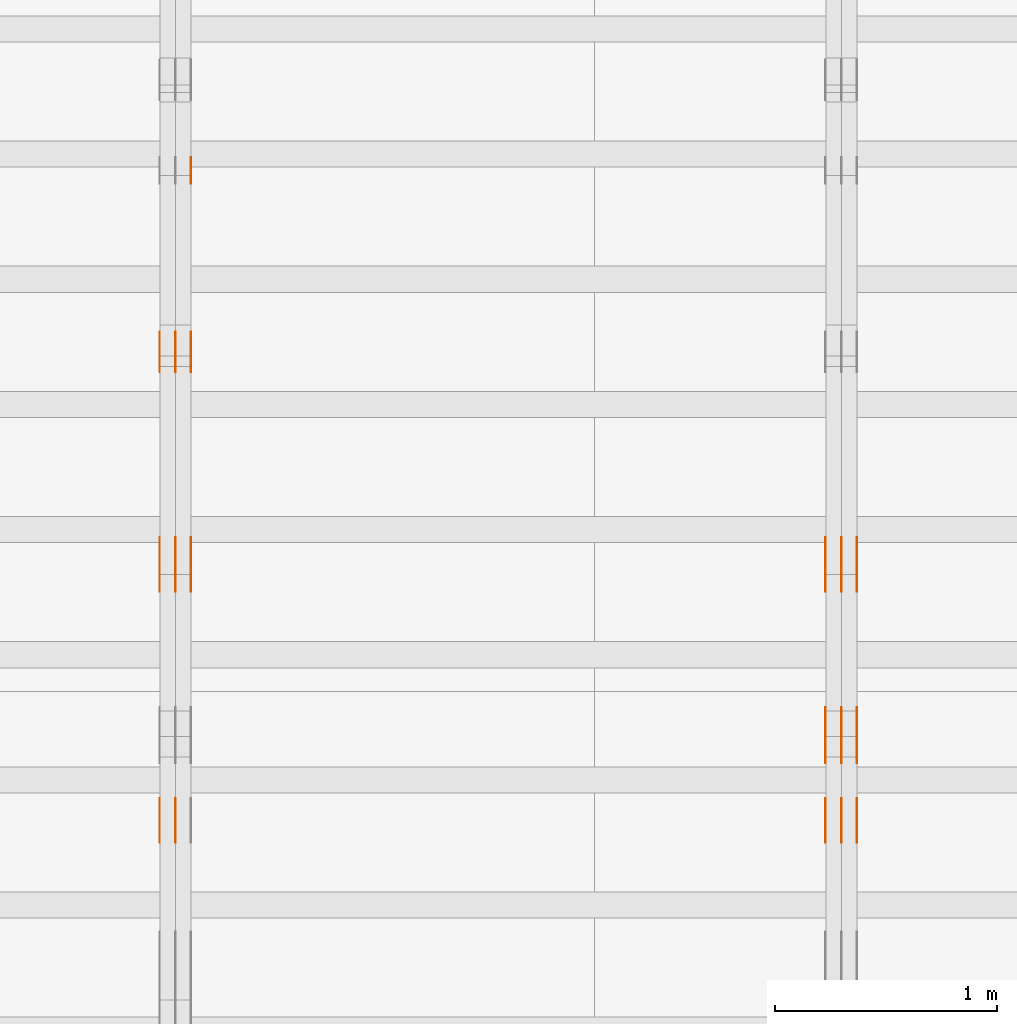
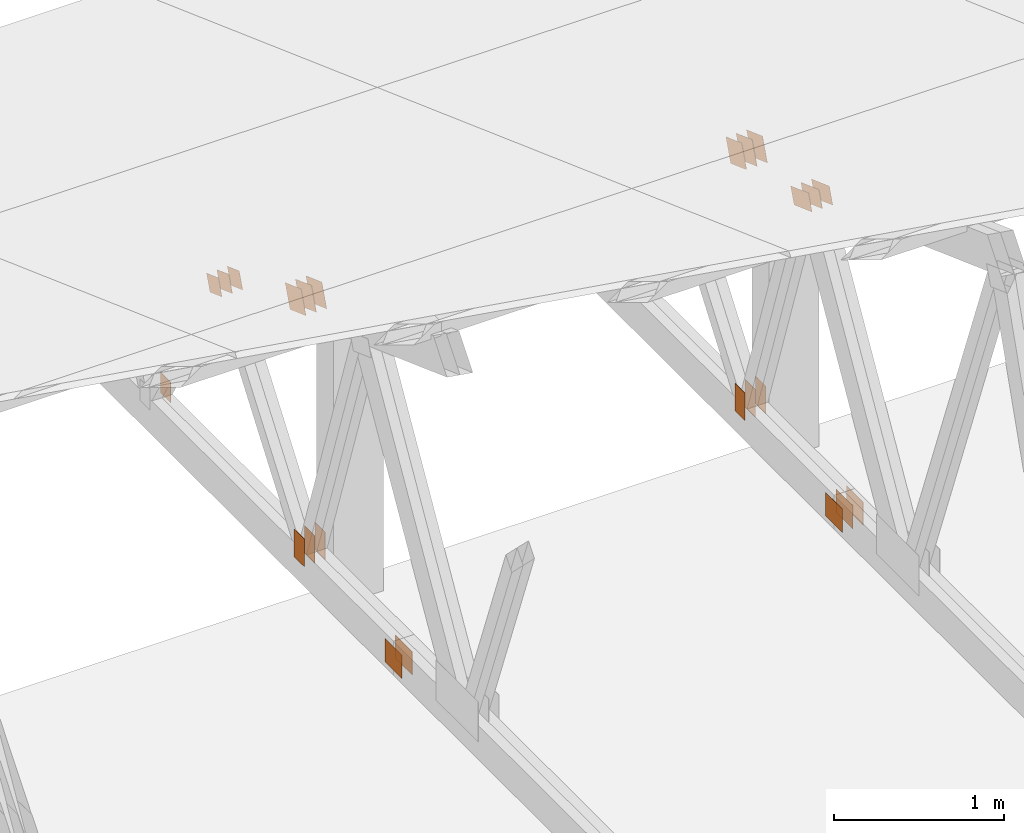
# One storey, part 112 of 189: 32 proxies.
"""IFC2X3 building model written with IfcOpenShell, lengths in millimetres."""

from ifc_helpers import new_model, entity, si_unit, converted_unit, derived_unit, direction, frame, frame_2d, origin, origin_2d_with_axis, place, context, subcontext, project, spatial, polyline, rectangle, outline, extrude, source, transform, mapped, material, type_object, type_shapes, element, save


model = new_model("IFC2X3")

# Units and contexts
model_context = context("Model", 3, precision=0.01, world=origin(), true_north=direction((6.12303176911189e-17, 1.0)))
body_context = subcontext(model_context, "Body", "Model", "MODEL_VIEW")
ifc_project = project(units=[si_unit("LENGTHUNIT", "METRE", prefix="MILLI"), si_unit("AREAUNIT", "SQUARE_METRE"), si_unit("VOLUMEUNIT", "CUBIC_METRE"), converted_unit("PLANEANGLEUNIT", "DEGREE", entity("IfcRatioMeasure", 0.0174532925199433), si_unit("PLANEANGLEUNIT", "RADIAN"), dimensions=[0, 0, 0, 0, 0, 0, 0]), si_unit("MASSUNIT", "GRAM", prefix="KILO"), derived_unit("MASSDENSITYUNIT", [(si_unit("MASSUNIT", "GRAM", prefix="KILO"), 1), (si_unit("LENGTHUNIT", "METRE"), -3)]), si_unit("TIMEUNIT", "SECOND"), si_unit("FREQUENCYUNIT", "HERTZ"), si_unit("THERMODYNAMICTEMPERATUREUNIT", "DEGREE_CELSIUS"), derived_unit("THERMALTRANSMITTANCEUNIT", [(si_unit("MASSUNIT", "GRAM", prefix="KILO"), 1), (si_unit("THERMODYNAMICTEMPERATUREUNIT", "KELVIN"), -1), (si_unit("TIMEUNIT", "SECOND"), -3)]), derived_unit("VOLUMETRICFLOWRATEUNIT", [(si_unit("LENGTHUNIT", "METRE"), 3), (si_unit("TIMEUNIT", "SECOND"), -1)]), si_unit("ELECTRICCURRENTUNIT", "AMPERE"), si_unit("ELECTRICVOLTAGEUNIT", "VOLT"), si_unit("POWERUNIT", "WATT"), si_unit("FORCEUNIT", "NEWTON"), si_unit("ILLUMINANCEUNIT", "LUX"), si_unit("LUMINOUSFLUXUNIT", "LUMEN"), si_unit("LUMINOUSINTENSITYUNIT", "CANDELA"), derived_unit("USERDEFINED", [(si_unit("MASSUNIT", "GRAM", prefix="KILO"), -1), (si_unit("LENGTHUNIT", "METRE"), -2), (si_unit("TIMEUNIT", "SECOND"), 3), (si_unit("LUMINOUSFLUXUNIT", "LUMEN"), 1)]), derived_unit("LINEARVELOCITYUNIT", [(si_unit("LENGTHUNIT", "METRE"), 1), (si_unit("TIMEUNIT", "SECOND"), -1)]), si_unit("PRESSUREUNIT", "PASCAL"), derived_unit("USERDEFINED", [(si_unit("LENGTHUNIT", "METRE"), -2), (si_unit("MASSUNIT", "GRAM", prefix="KILO"), 1), (si_unit("TIMEUNIT", "SECOND"), -2)])], contexts=[model_context])

# Site, building, storey
site_placement = place(None, origin())
site = spatial("IfcSite", under=ifc_project, at=site_placement, CompositionType="ELEMENT")
building_placement = place(site_placement, origin())
building = spatial("IfcBuilding", under=site, at=building_placement, CompositionType="ELEMENT")
storey_placement = place(building_placement, origin())
storey = spatial("IfcBuildingStorey", under=building, at=storey_placement, Name="Default", CompositionType="ELEMENT", Elevation=0.0)

# Proxies
ifc_material_1 = material(Name="IfcSurfaceStyle #43318")
building_element_proxy_type_1 = type_object("IfcBuildingElementProxyType", PredefinedType="NOTDEFINED", material=ifc_material_1)
shared_shape_1 = source(origin(), body_context, "Body", "SweptSolid", [
    extrude(outline(polyline([(-112.499846801582, -59.999986193028), (112.499924372729, -59.999986193028), (112.499888552087, 59.999986193028), (-112.499966123235, 59.999986193028), (-112.499846801582, -59.999986193028)])), frame((112.499989807712, 60.0001003787081, 0.0), z_axis=(0.0, 0.0, 1.0), x_axis=(-1.0, 0.0, 0.0)), (0.0, 0.0, 1.0), 1.3),
])
type_shapes(building_element_proxy_type_1, [shared_shape_1])
proxy_1_placement = place(building_placement, frame((6336.3, 24040.8868138992, 2049.61031693104), z_axis=(-1.0, 0.0, 0.0), x_axis=(0.0, -0.939692620785908, 0.342020143325669)))
element("IfcBuildingElementProxy", 1, at=proxy_1_placement, inside=storey, type_object=building_element_proxy_type_1, material=ifc_material_1, context=body_context, shape_type="MappedRepresentation", body=[
    mapped(shared_shape_1, transform((0.0, 0.0, 0.0), scale=1.0)),
])
ifc_material_2 = material(Name="IfcSurfaceStyle #43261")
building_element_proxy_type_2 = type_object("IfcBuildingElementProxyType", PredefinedType="NOTDEFINED", material=ifc_material_2)
shared_shape_2 = source(origin(), body_context, "Body", "SweptSolid", [
    extrude(outline(polyline([(-112.499846801582, -59.999986193028), (112.499924372729, -59.999986193028), (112.499888552087, 59.999986193028), (-112.499966123235, 59.999986193028), (-112.499846801582, -59.999986193028)])), frame((112.499989807712, 60.0001003787081, 0.0), z_axis=(0.0, 0.0, 1.0), x_axis=(-1.0, 0.0, 0.0)), (0.0, 0.0, 1.0), 1.29999999999998),
])
type_shapes(building_element_proxy_type_2, [shared_shape_2])
proxy_2_placement = place(building_placement, frame((6265.0, 24040.8868138992, 2049.61031693104), z_axis=(-1.0, 0.0, 0.0), x_axis=(0.0, -0.939692620785908, 0.342020143325669)))
element("IfcBuildingElementProxy", 2, at=proxy_2_placement, inside=storey, type_object=building_element_proxy_type_2, material=ifc_material_2, context=body_context, shape_type="MappedRepresentation", body=[
    mapped(shared_shape_2, transform((0.0, 0.0, 0.0), scale=1.0)),
])
ifc_material_3 = material(Name="IfcSurfaceStyle #43204")
building_element_proxy_type_3 = type_object("IfcBuildingElementProxyType", PredefinedType="NOTDEFINED", material=ifc_material_3)
shared_shape_3 = source(origin(), body_context, "Body", "SweptSolid", [
    extrude(outline(polyline([(-112.499846801582, -59.999986193028), (112.499924372729, -59.999986193028), (112.499888552087, 59.999986193028), (-112.499966123235, 59.999986193028), (-112.499846801582, -59.999986193028)])), frame((112.499989807712, 60.0001003787081, 0.0), z_axis=(0.0, 0.0, 1.0), x_axis=(-1.0, 0.0, 0.0)), (0.0, 0.0, 1.0), 1.29999999999998),
])
type_shapes(building_element_proxy_type_3, [shared_shape_3])
proxy_3_placement = place(building_placement, frame((6266.3, 24040.8868138992, 2049.61031693104), z_axis=(-1.0, 0.0, 0.0), x_axis=(0.0, -0.939692620785908, 0.342020143325669)))
element("IfcBuildingElementProxy", 3, at=proxy_3_placement, inside=storey, type_object=building_element_proxy_type_3, material=ifc_material_3, context=body_context, shape_type="MappedRepresentation", body=[
    mapped(shared_shape_3, transform((0.0, 0.0, 0.0), scale=1.0)),
])
ifc_material_4 = material(Name="IfcSurfaceStyle #43147")
building_element_proxy_type_4 = type_object("IfcBuildingElementProxyType", PredefinedType="NOTDEFINED", material=ifc_material_4)
shared_shape_4 = source(origin(), body_context, "Body", "SweptSolid", [
    extrude(outline(polyline([(-112.499846801582, -59.999986193028), (112.499924372729, -59.999986193028), (112.499888552087, 59.999986193028), (-112.499966123235, 59.999986193028), (-112.499846801582, -59.999986193028)])), frame((112.499989807712, 60.0001003787081, 0.0), z_axis=(0.0, 0.0, 1.0), x_axis=(-1.0, 0.0, 0.0)), (0.0, 0.0, 1.0), 1.29999999999999),
])
type_shapes(building_element_proxy_type_4, [shared_shape_4])
proxy_4_placement = place(building_placement, frame((6195.0, 24040.8868138992, 2049.61031693104), z_axis=(-1.0, 0.0, 0.0), x_axis=(0.0, -0.939692620785908, 0.342020143325669)))
element("IfcBuildingElementProxy", 4, at=proxy_4_placement, inside=storey, type_object=building_element_proxy_type_4, material=ifc_material_4, context=body_context, shape_type="MappedRepresentation", body=[
    mapped(shared_shape_4, transform((0.0, 0.0, 0.0), scale=1.0)),
])
ifc_material_5 = material(Name="IfcSurfaceStyle #43090")
building_element_proxy_type_5 = type_object("IfcBuildingElementProxyType", PredefinedType="NOTDEFINED", material=ifc_material_5)
shared_shape_5 = source(origin(), body_context, "Body", "SweptSolid", [
    extrude(rectangle(XDim=200.0, YDim=120.0, at=origin_2d_with_axis()), frame((100.0, 60.0002296775929, 0.0), z_axis=(0.0, 0.0, 1.0), x_axis=(-1.0, 0.0, 0.0)), (0.0, 0.0, 1.0), 1.3),
])
type_shapes(building_element_proxy_type_5, [shared_shape_5])
proxy_5_placement = place(building_placement, frame((6336.3, 24619.3435203224, 145.0), z_axis=(-1.0, 0.0, 0.0), x_axis=(0.0, 0.0, 1.0)))
element("IfcBuildingElementProxy", 5, at=proxy_5_placement, inside=storey, type_object=building_element_proxy_type_5, material=ifc_material_5, context=body_context, shape_type="MappedRepresentation", body=[
    mapped(shared_shape_5, transform((0.0, 0.0, 0.0), scale=1.0)),
])
ifc_material_6 = material(Name="IfcSurfaceStyle #43033")
building_element_proxy_type_6 = type_object("IfcBuildingElementProxyType", PredefinedType="NOTDEFINED", material=ifc_material_6)
shared_shape_6 = source(origin(), body_context, "Body", "SweptSolid", [
    extrude(rectangle(XDim=200.0, YDim=120.0, at=origin_2d_with_axis()), frame((100.0, 60.0002296775929, 0.0), z_axis=(0.0, 0.0, 1.0), x_axis=(-1.0, 0.0, 0.0)), (0.0, 0.0, 1.0), 1.29999999999998),
])
type_shapes(building_element_proxy_type_6, [shared_shape_6])
proxy_6_placement = place(building_placement, frame((6265.0, 24619.3435203224, 145.0), z_axis=(-1.0, 0.0, 0.0), x_axis=(0.0, 0.0, 1.0)))
element("IfcBuildingElementProxy", 6, at=proxy_6_placement, inside=storey, type_object=building_element_proxy_type_6, material=ifc_material_6, context=body_context, shape_type="MappedRepresentation", body=[
    mapped(shared_shape_6, transform((0.0, 0.0, 0.0), scale=1.0)),
])
ifc_material_7 = material(Name="IfcSurfaceStyle #42976")
building_element_proxy_type_7 = type_object("IfcBuildingElementProxyType", PredefinedType="NOTDEFINED", material=ifc_material_7)
shared_shape_7 = source(origin(), body_context, "Body", "SweptSolid", [
    extrude(rectangle(XDim=200.0, YDim=120.0, at=origin_2d_with_axis()), frame((100.0, 60.0002296775929, 0.0), z_axis=(0.0, 0.0, 1.0), x_axis=(-1.0, 0.0, 0.0)), (0.0, 0.0, 1.0), 1.29999999999998),
])
type_shapes(building_element_proxy_type_7, [shared_shape_7])
proxy_7_placement = place(building_placement, frame((6266.3, 24619.3435203224, 145.0), z_axis=(-1.0, 0.0, 0.0), x_axis=(0.0, 0.0, 1.0)))
element("IfcBuildingElementProxy", 7, at=proxy_7_placement, inside=storey, type_object=building_element_proxy_type_7, material=ifc_material_7, context=body_context, shape_type="MappedRepresentation", body=[
    mapped(shared_shape_7, transform((0.0, 0.0, 0.0), scale=1.0)),
])
ifc_material_8 = material(Name="IfcSurfaceStyle #42919")
building_element_proxy_type_8 = type_object("IfcBuildingElementProxyType", PredefinedType="NOTDEFINED", material=ifc_material_8)
shared_shape_8 = source(origin(), body_context, "Body", "SweptSolid", [
    extrude(rectangle(XDim=200.0, YDim=120.0, at=origin_2d_with_axis()), frame((100.0, 60.0002296775929, 0.0), z_axis=(0.0, 0.0, 1.0), x_axis=(-1.0, 0.0, 0.0)), (0.0, 0.0, 1.0), 1.29999999999999),
])
type_shapes(building_element_proxy_type_8, [shared_shape_8])
proxy_8_placement = place(building_placement, frame((6195.0, 24619.3435203224, 145.0), z_axis=(-1.0, 0.0, 0.0), x_axis=(0.0, 0.0, 1.0)))
element("IfcBuildingElementProxy", 8, at=proxy_8_placement, inside=storey, type_object=building_element_proxy_type_8, material=ifc_material_8, context=body_context, shape_type="MappedRepresentation", body=[
    mapped(shared_shape_8, transform((0.0, 0.0, 0.0), scale=1.0)),
])
ifc_material_9 = material(Name="IfcSurfaceStyle #39442")
building_element_proxy_type_9 = type_object("IfcBuildingElementProxyType", PredefinedType="NOTDEFINED", material=ifc_material_9)
shared_shape_9 = source(origin(), body_context, "Body", "SweptSolid", [
    extrude(rectangle(XDim=200.0, YDim=168.0, at=origin_2d_with_axis()), frame((100.0, 84.0, 0.0), z_axis=(0.0, 0.0, 1.0), x_axis=(-1.0, 0.0, 0.0)), (0.0, 0.0, 1.0), 1.3),
])
type_shapes(building_element_proxy_type_9, [shared_shape_9])
proxy_9_placement = place(building_placement, frame((6336.3, 23470.0, 206.5), z_axis=(-1.0, 0.0, 0.0), x_axis=(0.0, 1.0, 0.0)))
element("IfcBuildingElementProxy", 9, at=proxy_9_placement, inside=storey, type_object=building_element_proxy_type_9, material=ifc_material_9, context=body_context, shape_type="MappedRepresentation", body=[
    mapped(shared_shape_9, transform((0.0, 0.0, 0.0), scale=1.0)),
])
ifc_material_10 = material(Name="IfcSurfaceStyle #39385")
building_element_proxy_type_10 = type_object("IfcBuildingElementProxyType", PredefinedType="NOTDEFINED", material=ifc_material_10)
shared_shape_10 = source(origin(), body_context, "Body", "SweptSolid", [
    extrude(rectangle(XDim=200.0, YDim=168.0, at=origin_2d_with_axis()), frame((100.0, 84.0, 0.0), z_axis=(0.0, 0.0, 1.0), x_axis=(-1.0, 0.0, 0.0)), (0.0, 0.0, 1.0), 1.29999999999998),
])
type_shapes(building_element_proxy_type_10, [shared_shape_10])
proxy_10_placement = place(building_placement, frame((6265.0, 23470.0, 206.5), z_axis=(-1.0, 0.0, 0.0), x_axis=(0.0, 1.0, 0.0)))
element("IfcBuildingElementProxy", 10, at=proxy_10_placement, inside=storey, type_object=building_element_proxy_type_10, material=ifc_material_10, context=body_context, shape_type="MappedRepresentation", body=[
    mapped(shared_shape_10, transform((0.0, 0.0, 0.0), scale=1.0)),
])
ifc_material_11 = material(Name="IfcSurfaceStyle #39328")
building_element_proxy_type_11 = type_object("IfcBuildingElementProxyType", PredefinedType="NOTDEFINED", material=ifc_material_11)
shared_shape_11 = source(origin(), body_context, "Body", "SweptSolid", [
    extrude(rectangle(XDim=200.0, YDim=168.0, at=origin_2d_with_axis()), frame((100.0, 84.0, 0.0), z_axis=(0.0, 0.0, 1.0), x_axis=(-1.0, 0.0, 0.0)), (0.0, 0.0, 1.0), 1.29999999999998),
])
type_shapes(building_element_proxy_type_11, [shared_shape_11])
proxy_11_placement = place(building_placement, frame((6266.3, 23470.0, 206.5), z_axis=(-1.0, 0.0, 0.0), x_axis=(0.0, 1.0, 0.0)))
element("IfcBuildingElementProxy", 11, at=proxy_11_placement, inside=storey, type_object=building_element_proxy_type_11, material=ifc_material_11, context=body_context, shape_type="MappedRepresentation", body=[
    mapped(shared_shape_11, transform((0.0, 0.0, 0.0), scale=1.0)),
])
ifc_material_12 = material(Name="IfcSurfaceStyle #39271")
building_element_proxy_type_12 = type_object("IfcBuildingElementProxyType", PredefinedType="NOTDEFINED", material=ifc_material_12)
shared_shape_12 = source(origin(), body_context, "Body", "SweptSolid", [
    extrude(rectangle(XDim=200.0, YDim=168.0, at=origin_2d_with_axis()), frame((100.0, 84.0, 0.0), z_axis=(0.0, 0.0, 1.0), x_axis=(-1.0, 0.0, 0.0)), (0.0, 0.0, 1.0), 1.29999999999999),
])
type_shapes(building_element_proxy_type_12, [shared_shape_12])
proxy_12_placement = place(building_placement, frame((6195.0, 23470.0, 206.5), z_axis=(-1.0, 0.0, 0.0), x_axis=(0.0, 1.0, 0.0)))
element("IfcBuildingElementProxy", 12, at=proxy_12_placement, inside=storey, type_object=building_element_proxy_type_12, material=ifc_material_12, context=body_context, shape_type="MappedRepresentation", body=[
    mapped(shared_shape_12, transform((0.0, 0.0, 0.0), scale=1.0)),
])
ifc_material_13 = material(Name="IfcSurfaceStyle #37282")
building_element_proxy_type_13 = type_object("IfcBuildingElementProxyType", PredefinedType="NOTDEFINED", material=ifc_material_13)
shared_shape_13 = source(origin(), body_context, "Body", "SweptSolid", [
    extrude(outline(polyline([(-99.9999065788418, -84.0000755647729), (99.9999734279406, -84.0000755647729), (99.9999483293475, 84.000075564773), (-100.000015178446, 84.000075564773), (-99.9999065788418, -84.0000755647729)])), frame((100.000157783747, 84.0001144608011, 0.0), z_axis=(0.0, 0.0, 1.0), x_axis=(-1.0, 0.0, 0.0)), (0.0, 0.0, 1.0), 1.3),
])
type_shapes(building_element_proxy_type_13, [shared_shape_13])
proxy_13_placement = place(building_placement, frame((6336.3, 24788.4767593228, 1895.10136879206), z_axis=(-1.0, 0.0, 0.0), x_axis=(0.0, -0.939692620785908, 0.342020143325669)))
element("IfcBuildingElementProxy", 13, at=proxy_13_placement, inside=storey, type_object=building_element_proxy_type_13, material=ifc_material_13, context=body_context, shape_type="MappedRepresentation", body=[
    mapped(shared_shape_13, transform((0.0, 0.0, 0.0), scale=1.0)),
])
ifc_material_14 = material(Name="IfcSurfaceStyle #37225")
building_element_proxy_type_14 = type_object("IfcBuildingElementProxyType", PredefinedType="NOTDEFINED", material=ifc_material_14)
shared_shape_14 = source(origin(), body_context, "Body", "SweptSolid", [
    extrude(outline(polyline([(-99.9999065788418, -84.0000755647729), (99.9999734279406, -84.0000755647729), (99.9999483293475, 84.000075564773), (-100.000015178446, 84.000075564773), (-99.9999065788418, -84.0000755647729)])), frame((100.000157783747, 84.0001144608011, 0.0), z_axis=(0.0, 0.0, 1.0), x_axis=(-1.0, 0.0, 0.0)), (0.0, 0.0, 1.0), 1.29999999999998),
])
type_shapes(building_element_proxy_type_14, [shared_shape_14])
proxy_14_placement = place(building_placement, frame((6265.0, 24788.4767593228, 1895.10136879206), z_axis=(-1.0, 0.0, 0.0), x_axis=(0.0, -0.939692620785908, 0.342020143325669)))
element("IfcBuildingElementProxy", 14, at=proxy_14_placement, inside=storey, type_object=building_element_proxy_type_14, material=ifc_material_14, context=body_context, shape_type="MappedRepresentation", body=[
    mapped(shared_shape_14, transform((0.0, 0.0, 0.0), scale=1.0)),
])
ifc_material_15 = material(Name="IfcSurfaceStyle #37168")
building_element_proxy_type_15 = type_object("IfcBuildingElementProxyType", PredefinedType="NOTDEFINED", material=ifc_material_15)
shared_shape_15 = source(origin(), body_context, "Body", "SweptSolid", [
    extrude(outline(polyline([(-99.9999065788418, -84.0000755647729), (99.9999734279406, -84.0000755647729), (99.9999483293475, 84.000075564773), (-100.000015178446, 84.000075564773), (-99.9999065788418, -84.0000755647729)])), frame((100.000157783747, 84.0001144608011, 0.0), z_axis=(0.0, 0.0, 1.0), x_axis=(-1.0, 0.0, 0.0)), (0.0, 0.0, 1.0), 1.29999999999998),
])
type_shapes(building_element_proxy_type_15, [shared_shape_15])
proxy_15_placement = place(building_placement, frame((6266.3, 24788.4767593228, 1895.10136879206), z_axis=(-1.0, 0.0, 0.0), x_axis=(0.0, -0.939692620785908, 0.342020143325669)))
element("IfcBuildingElementProxy", 15, at=proxy_15_placement, inside=storey, type_object=building_element_proxy_type_15, material=ifc_material_15, context=body_context, shape_type="MappedRepresentation", body=[
    mapped(shared_shape_15, transform((0.0, 0.0, 0.0), scale=1.0)),
])
ifc_material_16 = material(Name="IfcSurfaceStyle #37111")
building_element_proxy_type_16 = type_object("IfcBuildingElementProxyType", PredefinedType="NOTDEFINED", material=ifc_material_16)
shared_shape_16 = source(origin(), body_context, "Body", "SweptSolid", [
    extrude(outline(polyline([(-99.9999065788418, -84.0000755647729), (99.9999734279406, -84.0000755647729), (99.9999483293475, 84.000075564773), (-100.000015178446, 84.000075564773), (-99.9999065788418, -84.0000755647729)])), frame((100.000157783747, 84.0001144608011, 0.0), z_axis=(0.0, 0.0, 1.0), x_axis=(-1.0, 0.0, 0.0)), (0.0, 0.0, 1.0), 1.29999999999999),
])
type_shapes(building_element_proxy_type_16, [shared_shape_16])
proxy_16_placement = place(building_placement, frame((6195.0, 24788.4767593228, 1895.10136879206), z_axis=(-1.0, 0.0, 0.0), x_axis=(0.0, -0.939692620785908, 0.342020143325669)))
element("IfcBuildingElementProxy", 16, at=proxy_16_placement, inside=storey, type_object=building_element_proxy_type_16, material=ifc_material_16, context=body_context, shape_type="MappedRepresentation", body=[
    mapped(shared_shape_16, transform((0.0, 0.0, 0.0), scale=1.0)),
])
ifc_material_17 = material(Name="IfcSurfaceStyle #27300")
building_element_proxy_type_17 = type_object("IfcBuildingElementProxyType", PredefinedType="NOTDEFINED", material=ifc_material_17)
shared_shape_17 = source(origin(), body_context, "Body", "SweptSolid", [
    extrude(rectangle(XDim=200.0, YDim=120.0, at=origin_2d_with_axis()), frame((100.0, 60.0002296775929, 0.0), z_axis=(0.0, 0.0, 1.0), x_axis=(-1.0, 0.0, 0.0)), (0.0, 0.0, 1.0), 1.3),
])
type_shapes(building_element_proxy_type_17, [shared_shape_17])
proxy_17_placement = place(building_placement, frame((3336.3, 24619.3435203224, 145.0), z_axis=(-1.0, 0.0, 0.0), x_axis=(0.0, 0.0, 1.0)))
element("IfcBuildingElementProxy", 17, at=proxy_17_placement, inside=storey, type_object=building_element_proxy_type_17, material=ifc_material_17, context=body_context, shape_type="MappedRepresentation", body=[
    mapped(shared_shape_17, transform((0.0, 0.0, 0.0), scale=1.0)),
])
ifc_material_18 = material(Name="IfcSurfaceStyle #27243")
building_element_proxy_type_18 = type_object("IfcBuildingElementProxyType", PredefinedType="NOTDEFINED", material=ifc_material_18)
shared_shape_18 = source(origin(), body_context, "Body", "SweptSolid", [
    extrude(rectangle(XDim=200.0, YDim=120.0, at=origin_2d_with_axis()), frame((100.0, 60.0002296775929, 0.0), z_axis=(0.0, 0.0, 1.0), x_axis=(-1.0, 0.0, 0.0)), (0.0, 0.0, 1.0), 1.29999999999998),
])
type_shapes(building_element_proxy_type_18, [shared_shape_18])
proxy_18_placement = place(building_placement, frame((3265.0, 24619.3435203224, 145.0), z_axis=(-1.0, 0.0, 0.0), x_axis=(0.0, 0.0, 1.0)))
element("IfcBuildingElementProxy", 18, at=proxy_18_placement, inside=storey, type_object=building_element_proxy_type_18, material=ifc_material_18, context=body_context, shape_type="MappedRepresentation", body=[
    mapped(shared_shape_18, transform((0.0, 0.0, 0.0), scale=1.0)),
])
ifc_material_19 = material(Name="IfcSurfaceStyle #27186")
building_element_proxy_type_19 = type_object("IfcBuildingElementProxyType", PredefinedType="NOTDEFINED", material=ifc_material_19)
shared_shape_19 = source(origin(), body_context, "Body", "SweptSolid", [
    extrude(rectangle(XDim=200.0, YDim=120.0, at=origin_2d_with_axis()), frame((100.0, 60.0002296775929, 0.0), z_axis=(0.0, 0.0, 1.0), x_axis=(-1.0, 0.0, 0.0)), (0.0, 0.0, 1.0), 1.29999999999998),
])
type_shapes(building_element_proxy_type_19, [shared_shape_19])
proxy_19_placement = place(building_placement, frame((3266.3, 24619.3435203224, 145.0), z_axis=(-1.0, 0.0, 0.0), x_axis=(0.0, 0.0, 1.0)))
element("IfcBuildingElementProxy", 19, at=proxy_19_placement, inside=storey, type_object=building_element_proxy_type_19, material=ifc_material_19, context=body_context, shape_type="MappedRepresentation", body=[
    mapped(shared_shape_19, transform((0.0, 0.0, 0.0), scale=1.0)),
])
ifc_material_20 = material(Name="IfcSurfaceStyle #27129")
building_element_proxy_type_20 = type_object("IfcBuildingElementProxyType", PredefinedType="NOTDEFINED", material=ifc_material_20)
shared_shape_20 = source(origin(), body_context, "Body", "SweptSolid", [
    extrude(rectangle(XDim=200.0, YDim=120.0, at=origin_2d_with_axis()), frame((100.0, 60.0002296775929, 0.0), z_axis=(0.0, 0.0, 1.0), x_axis=(-1.0, 0.0, 0.0)), (0.0, 0.0, 1.0), 1.29999999999999),
])
type_shapes(building_element_proxy_type_20, [shared_shape_20])
proxy_20_placement = place(building_placement, frame((3195.0, 24619.3435203224, 145.0), z_axis=(-1.0, 0.0, 0.0), x_axis=(0.0, 0.0, 1.0)))
element("IfcBuildingElementProxy", 20, at=proxy_20_placement, inside=storey, type_object=building_element_proxy_type_20, material=ifc_material_20, context=body_context, shape_type="MappedRepresentation", body=[
    mapped(shared_shape_20, transform((0.0, 0.0, 0.0), scale=1.0)),
])
ifc_material_21 = material(Name="IfcSurfaceStyle #26616")
building_element_proxy_type_21 = type_object("IfcBuildingElementProxyType", PredefinedType="NOTDEFINED", material=ifc_material_21)
shared_shape_21 = source(origin(), body_context, "Body", "SweptSolid", [
    extrude(outline(polyline([(-74.9999475298494, -60.0), (75.0000042257432, -60.0), (74.9999684051025, 60.0), (-75.0000251009963, 60.0), (-74.9999475298494, -60.0)])), frame((75.0000607644577, 60.0000865490217, 0.0), z_axis=(0.0, 0.0, 1.0), x_axis=(-1.0, 0.0, 0.0)), (0.0, 0.0, 1.0), 1.3),
])
type_shapes(building_element_proxy_type_21, [shared_shape_21])
proxy_21_placement = place(building_placement, frame((3336.3, 25732.0586805394, 1446.84420669249), z_axis=(-1.0, 0.0, 0.0), x_axis=(0.0, -0.939692620785908, 0.342020143325669)))
element("IfcBuildingElementProxy", 21, at=proxy_21_placement, inside=storey, type_object=building_element_proxy_type_21, material=ifc_material_21, context=body_context, shape_type="MappedRepresentation", body=[
    mapped(shared_shape_21, transform((0.0, 0.0, 0.0), scale=1.0)),
])
ifc_material_22 = material(Name="IfcSurfaceStyle #26559")
building_element_proxy_type_22 = type_object("IfcBuildingElementProxyType", PredefinedType="NOTDEFINED", material=ifc_material_22)
shared_shape_22 = source(origin(), body_context, "Body", "SweptSolid", [
    extrude(outline(polyline([(-74.9999475298494, -60.0), (75.0000042257432, -60.0), (74.9999684051025, 60.0), (-75.0000251009963, 60.0), (-74.9999475298494, -60.0)])), frame((75.0000607644577, 60.0000865490217, 0.0), z_axis=(0.0, 0.0, 1.0), x_axis=(-1.0, 0.0, 0.0)), (0.0, 0.0, 1.0), 1.29999999999999),
])
type_shapes(building_element_proxy_type_22, [shared_shape_22])
proxy_22_placement = place(building_placement, frame((3265.0, 25732.0586805394, 1446.84420669249), z_axis=(-1.0, 0.0, 0.0), x_axis=(0.0, -0.939692620785908, 0.342020143325669)))
element("IfcBuildingElementProxy", 22, at=proxy_22_placement, inside=storey, type_object=building_element_proxy_type_22, material=ifc_material_22, context=body_context, shape_type="MappedRepresentation", body=[
    mapped(shared_shape_22, transform((0.0, 0.0, 0.0), scale=1.0)),
])
ifc_material_23 = material(Name="IfcSurfaceStyle #26502")
building_element_proxy_type_23 = type_object("IfcBuildingElementProxyType", PredefinedType="NOTDEFINED", material=ifc_material_23)
shared_shape_23 = source(origin(), body_context, "Body", "SweptSolid", [
    extrude(outline(polyline([(-74.9999475298494, -60.0), (75.0000042257432, -60.0), (74.9999684051025, 60.0), (-75.0000251009963, 60.0), (-74.9999475298494, -60.0)])), frame((75.0000607644577, 60.0000865490217, 0.0), z_axis=(0.0, 0.0, 1.0), x_axis=(-1.0, 0.0, 0.0)), (0.0, 0.0, 1.0), 1.29999999999999),
])
type_shapes(building_element_proxy_type_23, [shared_shape_23])
proxy_23_placement = place(building_placement, frame((3266.3, 25732.0586805394, 1446.84420669249), z_axis=(-1.0, 0.0, 0.0), x_axis=(0.0, -0.939692620785908, 0.342020143325669)))
element("IfcBuildingElementProxy", 23, at=proxy_23_placement, inside=storey, type_object=building_element_proxy_type_23, material=ifc_material_23, context=body_context, shape_type="MappedRepresentation", body=[
    mapped(shared_shape_23, transform((0.0, 0.0, 0.0), scale=1.0)),
])
ifc_material_24 = material(Name="IfcSurfaceStyle #26445")
building_element_proxy_type_24 = type_object("IfcBuildingElementProxyType", PredefinedType="NOTDEFINED", material=ifc_material_24)
shared_shape_24 = source(origin(), body_context, "Body", "SweptSolid", [
    extrude(outline(polyline([(-74.9999475298494, -60.0), (75.0000042257432, -60.0), (74.9999684051025, 60.0), (-75.0000251009963, 60.0), (-74.9999475298494, -60.0)])), frame((75.0000607644577, 60.0000865490217, 0.0), z_axis=(0.0, 0.0, 1.0), x_axis=(-1.0, 0.0, 0.0)), (0.0, 0.0, 1.0), 1.29999999999999),
])
type_shapes(building_element_proxy_type_24, [shared_shape_24])
proxy_24_placement = place(building_placement, frame((3195.0, 25732.0586805394, 1446.84420669249), z_axis=(-1.0, 0.0, 0.0), x_axis=(0.0, -0.939692620785908, 0.342020143325669)))
element("IfcBuildingElementProxy", 24, at=proxy_24_placement, inside=storey, type_object=building_element_proxy_type_24, material=ifc_material_24, context=body_context, shape_type="MappedRepresentation", body=[
    mapped(shared_shape_24, transform((0.0, 0.0, 0.0), scale=1.0)),
])
ifc_material_25 = material(Name="IfcSurfaceStyle #26388")
building_element_proxy_type_25 = type_object("IfcBuildingElementProxyType", PredefinedType="NOTDEFINED", material=ifc_material_25)
shared_shape_25 = source(origin(), body_context, "Body", "SweptSolid", [
    extrude(rectangle(XDim=150.0, YDim=120.0, at=frame_2d((-7.105427357601e-15, 0.0), x_axis=(1.0, 0.0))), frame((75.0, 60.0, 0.0), z_axis=(0.0, 0.0, 1.0), x_axis=(-1.0, 0.0, 0.0)), (0.0, 0.0, 1.0), 1.3),
])
type_shapes(building_element_proxy_type_25, [shared_shape_25])
proxy_25_placement = place(building_placement, frame((3336.3, 26439.0083007813, 170.0), z_axis=(-1.0, 0.0, 0.0), x_axis=(0.0, 0.0, 1.0)))
element("IfcBuildingElementProxy", 25, at=proxy_25_placement, inside=storey, type_object=building_element_proxy_type_25, material=ifc_material_25, context=body_context, shape_type="MappedRepresentation", body=[
    mapped(shared_shape_25, transform((0.0, 0.0, 0.0), scale=1.0)),
])
ifc_material_26 = material(Name="IfcSurfaceStyle #23595")
building_element_proxy_type_26 = type_object("IfcBuildingElementProxyType", PredefinedType="NOTDEFINED", material=ifc_material_26)
shared_shape_26 = source(origin(), body_context, "Body", "SweptSolid", [
    extrude(rectangle(XDim=200.0, YDim=168.0, at=origin_2d_with_axis()), frame((100.0, 84.0, 0.0), z_axis=(0.0, 0.0, 1.0), x_axis=(-1.0, 0.0, 0.0)), (0.0, 0.0, 1.0), 1.29999999999998),
])
type_shapes(building_element_proxy_type_26, [shared_shape_26])
proxy_26_placement = place(building_placement, frame((3265.0, 23470.0, 206.5), z_axis=(-1.0, 0.0, 0.0), x_axis=(0.0, 1.0, 0.0)))
element("IfcBuildingElementProxy", 26, at=proxy_26_placement, inside=storey, type_object=building_element_proxy_type_26, material=ifc_material_26, context=body_context, shape_type="MappedRepresentation", body=[
    mapped(shared_shape_26, transform((0.0, 0.0, 0.0), scale=1.0)),
])
ifc_material_27 = material(Name="IfcSurfaceStyle #23538")
building_element_proxy_type_27 = type_object("IfcBuildingElementProxyType", PredefinedType="NOTDEFINED", material=ifc_material_27)
shared_shape_27 = source(origin(), body_context, "Body", "SweptSolid", [
    extrude(rectangle(XDim=200.0, YDim=168.0, at=origin_2d_with_axis()), frame((100.0, 84.0, 0.0), z_axis=(0.0, 0.0, 1.0), x_axis=(-1.0, 0.0, 0.0)), (0.0, 0.0, 1.0), 1.29999999999998),
])
type_shapes(building_element_proxy_type_27, [shared_shape_27])
proxy_27_placement = place(building_placement, frame((3266.3, 23470.0, 206.5), z_axis=(-1.0, 0.0, 0.0), x_axis=(0.0, 1.0, 0.0)))
element("IfcBuildingElementProxy", 27, at=proxy_27_placement, inside=storey, type_object=building_element_proxy_type_27, material=ifc_material_27, context=body_context, shape_type="MappedRepresentation", body=[
    mapped(shared_shape_27, transform((0.0, 0.0, 0.0), scale=1.0)),
])
ifc_material_28 = material(Name="IfcSurfaceStyle #23481")
building_element_proxy_type_28 = type_object("IfcBuildingElementProxyType", PredefinedType="NOTDEFINED", material=ifc_material_28)
shared_shape_28 = source(origin(), body_context, "Body", "SweptSolid", [
    extrude(rectangle(XDim=200.0, YDim=168.0, at=origin_2d_with_axis()), frame((100.0, 84.0, 0.0), z_axis=(0.0, 0.0, 1.0), x_axis=(-1.0, 0.0, 0.0)), (0.0, 0.0, 1.0), 1.29999999999999),
])
type_shapes(building_element_proxy_type_28, [shared_shape_28])
proxy_28_placement = place(building_placement, frame((3195.0, 23470.0, 206.5), z_axis=(-1.0, 0.0, 0.0), x_axis=(0.0, 1.0, 0.0)))
element("IfcBuildingElementProxy", 28, at=proxy_28_placement, inside=storey, type_object=building_element_proxy_type_28, material=ifc_material_28, context=body_context, shape_type="MappedRepresentation", body=[
    mapped(shared_shape_28, transform((0.0, 0.0, 0.0), scale=1.0)),
])
ifc_material_29 = material(Name="IfcSurfaceStyle #21492")
building_element_proxy_type_29 = type_object("IfcBuildingElementProxyType", PredefinedType="NOTDEFINED", material=ifc_material_29)
shared_shape_29 = source(origin(), body_context, "Body", "SweptSolid", [
    extrude(outline(polyline([(-99.9999065788418, -84.0000755647729), (99.9999734279406, -84.0000755647729), (99.9999483293475, 84.000075564773), (-100.000015178446, 84.000075564773), (-99.9999065788418, -84.0000755647729)])), frame((100.000157783747, 84.0001144608011, 0.0), z_axis=(0.0, 0.0, 1.0), x_axis=(-1.0, 0.0, 0.0)), (0.0, 0.0, 1.0), 1.3),
])
type_shapes(building_element_proxy_type_29, [shared_shape_29])
proxy_29_placement = place(building_placement, frame((3336.3, 24788.4767593228, 1895.10136879206), z_axis=(-1.0, 0.0, 0.0), x_axis=(0.0, -0.939692620785908, 0.342020143325669)))
element("IfcBuildingElementProxy", 29, at=proxy_29_placement, inside=storey, type_object=building_element_proxy_type_29, material=ifc_material_29, context=body_context, shape_type="MappedRepresentation", body=[
    mapped(shared_shape_29, transform((0.0, 0.0, 0.0), scale=1.0)),
])
ifc_material_30 = material(Name="IfcSurfaceStyle #21435")
building_element_proxy_type_30 = type_object("IfcBuildingElementProxyType", PredefinedType="NOTDEFINED", material=ifc_material_30)
shared_shape_30 = source(origin(), body_context, "Body", "SweptSolid", [
    extrude(outline(polyline([(-99.9999065788418, -84.0000755647729), (99.9999734279406, -84.0000755647729), (99.9999483293475, 84.000075564773), (-100.000015178446, 84.000075564773), (-99.9999065788418, -84.0000755647729)])), frame((100.000157783747, 84.0001144608011, 0.0), z_axis=(0.0, 0.0, 1.0), x_axis=(-1.0, 0.0, 0.0)), (0.0, 0.0, 1.0), 1.29999999999998),
])
type_shapes(building_element_proxy_type_30, [shared_shape_30])
proxy_30_placement = place(building_placement, frame((3265.0, 24788.4767593228, 1895.10136879206), z_axis=(-1.0, 0.0, 0.0), x_axis=(0.0, -0.939692620785908, 0.342020143325669)))
element("IfcBuildingElementProxy", 30, at=proxy_30_placement, inside=storey, type_object=building_element_proxy_type_30, material=ifc_material_30, context=body_context, shape_type="MappedRepresentation", body=[
    mapped(shared_shape_30, transform((0.0, 0.0, 0.0), scale=1.0)),
])
ifc_material_31 = material(Name="IfcSurfaceStyle #21378")
building_element_proxy_type_31 = type_object("IfcBuildingElementProxyType", PredefinedType="NOTDEFINED", material=ifc_material_31)
shared_shape_31 = source(origin(), body_context, "Body", "SweptSolid", [
    extrude(outline(polyline([(-99.9999065788418, -84.0000755647729), (99.9999734279406, -84.0000755647729), (99.9999483293475, 84.000075564773), (-100.000015178446, 84.000075564773), (-99.9999065788418, -84.0000755647729)])), frame((100.000157783747, 84.0001144608011, 0.0), z_axis=(0.0, 0.0, 1.0), x_axis=(-1.0, 0.0, 0.0)), (0.0, 0.0, 1.0), 1.29999999999998),
])
type_shapes(building_element_proxy_type_31, [shared_shape_31])
proxy_31_placement = place(building_placement, frame((3266.3, 24788.4767593228, 1895.10136879206), z_axis=(-1.0, 0.0, 0.0), x_axis=(0.0, -0.939692620785908, 0.342020143325669)))
element("IfcBuildingElementProxy", 31, at=proxy_31_placement, inside=storey, type_object=building_element_proxy_type_31, material=ifc_material_31, context=body_context, shape_type="MappedRepresentation", body=[
    mapped(shared_shape_31, transform((0.0, 0.0, 0.0), scale=1.0)),
])
ifc_material_32 = material(Name="IfcSurfaceStyle #21321")
building_element_proxy_type_32 = type_object("IfcBuildingElementProxyType", PredefinedType="NOTDEFINED", material=ifc_material_32)
shared_shape_32 = source(origin(), body_context, "Body", "SweptSolid", [
    extrude(outline(polyline([(-99.9999065788418, -84.0000755647729), (99.9999734279406, -84.0000755647729), (99.9999483293475, 84.000075564773), (-100.000015178446, 84.000075564773), (-99.9999065788418, -84.0000755647729)])), frame((100.000157783747, 84.0001144608011, 0.0), z_axis=(0.0, 0.0, 1.0), x_axis=(-1.0, 0.0, 0.0)), (0.0, 0.0, 1.0), 1.29999999999999),
])
type_shapes(building_element_proxy_type_32, [shared_shape_32])
proxy_32_placement = place(building_placement, frame((3195.0, 24788.4767593228, 1895.10136879206), z_axis=(-1.0, 0.0, 0.0), x_axis=(0.0, -0.939692620785908, 0.342020143325669)))
element("IfcBuildingElementProxy", 32, at=proxy_32_placement, inside=storey, type_object=building_element_proxy_type_32, material=ifc_material_32, context=body_context, shape_type="MappedRepresentation", body=[
    mapped(shared_shape_32, transform((0.0, 0.0, 0.0), scale=1.0)),
])

save(model, "model.ifc")
